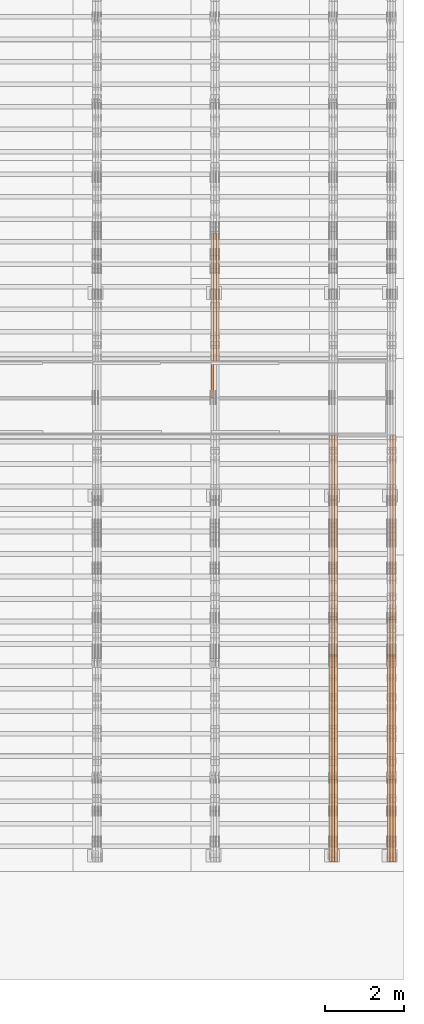
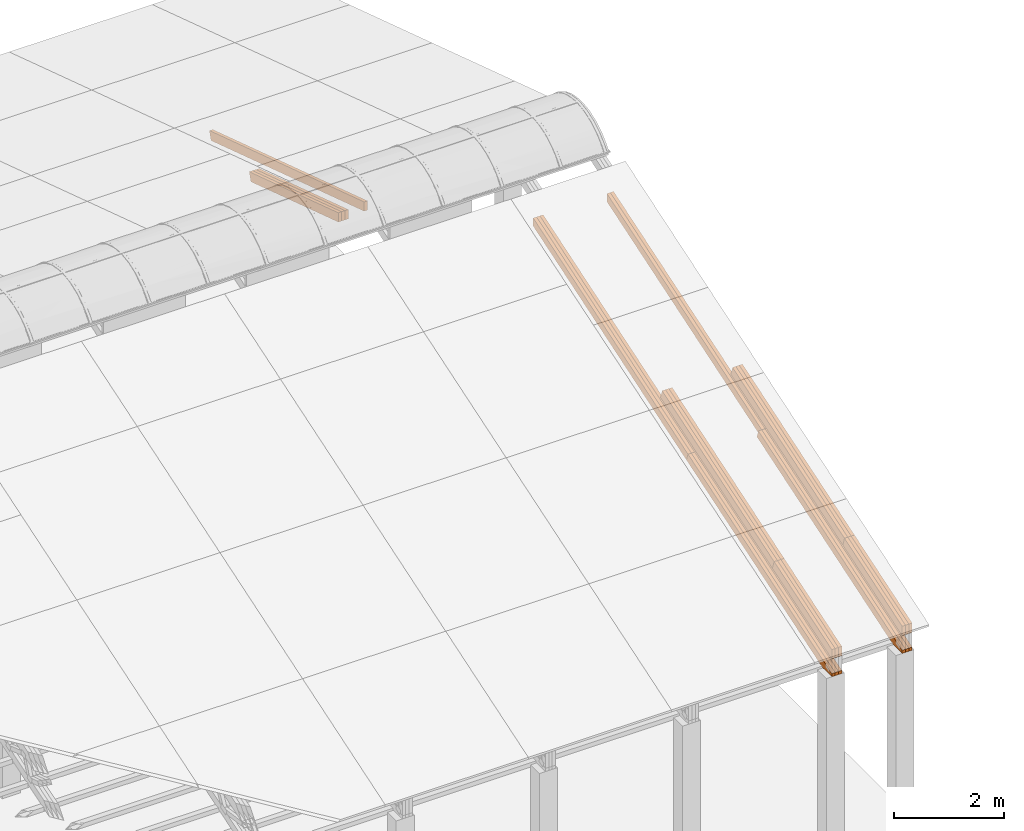
# One storey, part 28 of 385: 27 proxies.
"""IFC2X3 building model written with IfcOpenShell, lengths in millimetres."""

from ifc_helpers import new_model, entity, si_unit, converted_unit, derived_unit, direction, frame, origin, place, context, subcontext, project, spatial, polyline, outline, extrude, source, transform, mapped, material, type_object, type_shapes, element, save


model = new_model("IFC2X3")

# Units and contexts
model_context = context("Model", 3, precision=0.01, world=origin(), true_north=direction((6.12303176911189e-17, 1.0)))
body_context = subcontext(model_context, "Body", "Model", "MODEL_VIEW")
ifc_project = project(units=[si_unit("LENGTHUNIT", "METRE", prefix="MILLI"), si_unit("AREAUNIT", "SQUARE_METRE"), si_unit("VOLUMEUNIT", "CUBIC_METRE"), converted_unit("PLANEANGLEUNIT", "DEGREE", entity("IfcRatioMeasure", 0.0174532925199433), si_unit("PLANEANGLEUNIT", "RADIAN"), dimensions=[0, 0, 0, 0, 0, 0, 0]), si_unit("MASSUNIT", "GRAM", prefix="KILO"), derived_unit("MASSDENSITYUNIT", [(si_unit("MASSUNIT", "GRAM", prefix="KILO"), 1), (si_unit("LENGTHUNIT", "METRE"), -3)]), si_unit("TIMEUNIT", "SECOND"), si_unit("FREQUENCYUNIT", "HERTZ"), si_unit("THERMODYNAMICTEMPERATUREUNIT", "DEGREE_CELSIUS"), derived_unit("THERMALTRANSMITTANCEUNIT", [(si_unit("MASSUNIT", "GRAM", prefix="KILO"), 1), (si_unit("THERMODYNAMICTEMPERATUREUNIT", "KELVIN"), -1), (si_unit("TIMEUNIT", "SECOND"), -3)]), derived_unit("VOLUMETRICFLOWRATEUNIT", [(si_unit("LENGTHUNIT", "METRE"), 3), (si_unit("TIMEUNIT", "SECOND"), -1)]), si_unit("ELECTRICCURRENTUNIT", "AMPERE"), si_unit("ELECTRICVOLTAGEUNIT", "VOLT"), si_unit("POWERUNIT", "WATT"), si_unit("FORCEUNIT", "NEWTON", prefix="KILO"), si_unit("ILLUMINANCEUNIT", "LUX"), si_unit("LUMINOUSFLUXUNIT", "LUMEN"), si_unit("LUMINOUSINTENSITYUNIT", "CANDELA"), derived_unit("USERDEFINED", [(si_unit("MASSUNIT", "GRAM", prefix="KILO"), -1), (si_unit("LENGTHUNIT", "METRE"), -2), (si_unit("TIMEUNIT", "SECOND"), 3), (si_unit("LUMINOUSFLUXUNIT", "LUMEN"), 1)]), derived_unit("LINEARVELOCITYUNIT", [(si_unit("LENGTHUNIT", "METRE"), 1), (si_unit("TIMEUNIT", "SECOND"), -1)]), si_unit("PRESSUREUNIT", "PASCAL"), derived_unit("USERDEFINED", [(si_unit("LENGTHUNIT", "METRE"), -2), (si_unit("MASSUNIT", "GRAM", prefix="KILO"), 1), (si_unit("TIMEUNIT", "SECOND"), -2)])], contexts=[model_context])

# Site, building, storey
site_placement = place(None, origin())
site = spatial("IfcSite", under=ifc_project, at=site_placement, CompositionType="ELEMENT")
building_placement = place(site_placement, origin())
building = spatial("IfcBuilding", under=site, at=building_placement, CompositionType="ELEMENT")
storey_placement = place(building_placement, origin())
storey = spatial("IfcBuildingStorey", under=building, at=storey_placement, Name="Default", CompositionType="ELEMENT", Elevation=0.0)

# Proxies
ifc_material_1 = material(Name="IfcSurfaceStyle #593191")
building_element_proxy_type_1 = type_object("IfcBuildingElementProxyType", Name="T2-T3 593189", PredefinedType="NOTDEFINED", material=ifc_material_1)
shared_shape_1 = source(origin(), body_context, "Body", "SweptSolid", [
    extrude(outline(polyline([(-1085.54462735035, -97.5001496742589), (1117.22361141796, -97.5001496742589), (1117.22498157786, 97.5001496742589), (-1148.90396564547, 97.5001496742589), (-1085.54462735035, -97.5001496742589)])), frame((1117.22498157786, 97.5001496742589, 0.0), z_axis=(0.0, 0.0, 1.0), x_axis=(-1.0, 0.0, 0.0)), (0.0, 0.0, 1.0), 69.9999999999999),
])
type_shapes(building_element_proxy_type_1, [shared_shape_1])
proxy_1_placement = place(building_placement, frame((49860.0, 5095.216796875, 1095.23693847656), z_axis=(-1.0, 0.0, 0.0), x_axis=(0.0, -0.951056516295154, -0.309016994374948)))
element("IfcBuildingElementProxy", 1, at=proxy_1_placement, inside=storey, type_object=building_element_proxy_type_1, material=ifc_material_1, Name="T2-T3", context=body_context, shape_type="MappedRepresentation", body=[
    mapped(shared_shape_1, transform((0.0, 0.0, 0.0), scale=1.0)),
])
ifc_material_2 = material(Name="IfcSurfaceStyle #593134")
building_element_proxy_type_2 = type_object("IfcBuildingElementProxyType", Name="T2-T3 593132", PredefinedType="NOTDEFINED", material=ifc_material_2)
shared_shape_2 = source(origin(), body_context, "Body", "SweptSolid", [
    extrude(outline(polyline([(-1085.54462735035, -97.5001496742589), (1117.22361141796, -97.5001496742589), (1117.22498157786, 97.5001496742589), (-1148.90396564547, 97.5001496742589), (-1085.54462735035, -97.5001496742589)])), frame((1117.22498157786, 97.5001496742589, 0.0), z_axis=(0.0, 0.0, 1.0), x_axis=(-1.0, 0.0, 0.0)), (0.0, 0.0, 1.0), 69.9999999999999),
])
type_shapes(building_element_proxy_type_2, [shared_shape_2])
proxy_2_placement = place(building_placement, frame((49790.0, 5095.216796875, 1095.23693847656), z_axis=(-1.0, 0.0, 0.0), x_axis=(0.0, -0.951056516295154, -0.309016994374948)))
element("IfcBuildingElementProxy", 2, at=proxy_2_placement, inside=storey, type_object=building_element_proxy_type_2, material=ifc_material_2, Name="T2-T3", context=body_context, shape_type="MappedRepresentation", body=[
    mapped(shared_shape_2, transform((0.0, 0.0, 0.0), scale=1.0)),
])
ifc_material_3 = material(Name="IfcSurfaceStyle #593077")
building_element_proxy_type_3 = type_object("IfcBuildingElementProxyType", Name="T2-T3 593075", PredefinedType="NOTDEFINED", material=ifc_material_3)
shared_shape_3 = source(origin(), body_context, "Body", "SweptSolid", [
    extrude(outline(polyline([(-1085.54462735035, -97.5001496742589), (1117.22361141796, -97.5001496742589), (1117.22498157786, 97.5001496742589), (-1148.90396564547, 97.5001496742589), (-1085.54462735035, -97.5001496742589)])), frame((1117.22498157786, 97.5001496742589, 0.0), z_axis=(0.0, 0.0, 1.0), x_axis=(-1.0, 0.0, 0.0)), (0.0, 0.0, 1.0), 69.9999999999999),
])
type_shapes(building_element_proxy_type_3, [shared_shape_3])
proxy_3_placement = place(building_placement, frame((49720.0, 5095.216796875, 1095.23693847656), z_axis=(-1.0, 0.0, 0.0), x_axis=(0.0, -0.951056516295154, -0.309016994374948)))
element("IfcBuildingElementProxy", 3, at=proxy_3_placement, inside=storey, type_object=building_element_proxy_type_3, material=ifc_material_3, Name="T2-T3", context=body_context, shape_type="MappedRepresentation", body=[
    mapped(shared_shape_3, transform((0.0, 0.0, 0.0), scale=1.0)),
])
ifc_material_4 = material(Name="IfcSurfaceStyle #593020")
building_element_proxy_type_4 = type_object("IfcBuildingElementProxyType", Name="T2-T2 593018", PredefinedType="NOTDEFINED", material=ifc_material_4)
shared_shape_4 = source(origin(), body_context, "Body", "SweptSolid", [
    extrude(outline(polyline([(-2137.04475371072, -97.5001541485635), (2137.04431231695, -97.5001541485635), (2137.0438249446, 97.5001541485636), (-2137.04338355082, 97.5001541485635), (-2137.04475371072, -97.5001541485635)])), frame((2137.04431231695, 97.5003268035489, 0.0), z_axis=(0.0, 0.0, 1.0), x_axis=(-1.0, 0.0, 0.0)), (0.0, 0.0, 1.0), 69.9999999999997),
])
type_shapes(building_element_proxy_type_4, [shared_shape_4])
proxy_4_placement = place(building_placement, frame((49860.0, 9160.11575124697, 2416.00267194857), z_axis=(-1.0, 0.0, 0.0), x_axis=(0.0, -0.951056516295154, -0.309016994374948)))
element("IfcBuildingElementProxy", 4, at=proxy_4_placement, inside=storey, type_object=building_element_proxy_type_4, material=ifc_material_4, Name="T2-T2", context=body_context, shape_type="MappedRepresentation", body=[
    mapped(shared_shape_4, transform((0.0, 0.0, 0.0), scale=1.0)),
])
ifc_material_5 = material(Name="IfcSurfaceStyle #592963")
building_element_proxy_type_5 = type_object("IfcBuildingElementProxyType", Name="T2-T2 592961", PredefinedType="NOTDEFINED", material=ifc_material_5)
shared_shape_5 = source(origin(), body_context, "Body", "SweptSolid", [
    extrude(outline(polyline([(-2137.04475371072, -97.5001541485635), (2137.04431231695, -97.5001541485635), (2137.0438249446, 97.5001541485636), (-2137.04338355082, 97.5001541485635), (-2137.04475371072, -97.5001541485635)])), frame((2137.04431231695, 97.5003268035489, 0.0), z_axis=(0.0, 0.0, 1.0), x_axis=(-1.0, 0.0, 0.0)), (0.0, 0.0, 1.0), 69.9999999999997),
])
type_shapes(building_element_proxy_type_5, [shared_shape_5])
proxy_5_placement = place(building_placement, frame((49790.0, 9160.11575124697, 2416.00267194857), z_axis=(-1.0, 0.0, 0.0), x_axis=(0.0, -0.951056516295154, -0.309016994374948)))
element("IfcBuildingElementProxy", 5, at=proxy_5_placement, inside=storey, type_object=building_element_proxy_type_5, material=ifc_material_5, Name="T2-T2", context=body_context, shape_type="MappedRepresentation", body=[
    mapped(shared_shape_5, transform((0.0, 0.0, 0.0), scale=1.0)),
])
ifc_material_6 = material(Name="IfcSurfaceStyle #592906")
building_element_proxy_type_6 = type_object("IfcBuildingElementProxyType", Name="T2-T2 592904", PredefinedType="NOTDEFINED", material=ifc_material_6)
shared_shape_6 = source(origin(), body_context, "Body", "SweptSolid", [
    extrude(outline(polyline([(-2137.04475371072, -97.5001541485635), (2137.04431231695, -97.5001541485635), (2137.0438249446, 97.5001541485636), (-2137.04338355082, 97.5001541485635), (-2137.04475371072, -97.5001541485635)])), frame((2137.04431231695, 97.5003268035489, 0.0), z_axis=(0.0, 0.0, 1.0), x_axis=(-1.0, 0.0, 0.0)), (0.0, 0.0, 1.0), 69.9999999999997),
])
type_shapes(building_element_proxy_type_6, [shared_shape_6])
proxy_6_placement = place(building_placement, frame((49720.0, 9160.11575124697, 2416.00267194857), z_axis=(-1.0, 0.0, 0.0), x_axis=(0.0, -0.951056516295154, -0.309016994374948)))
element("IfcBuildingElementProxy", 6, at=proxy_6_placement, inside=storey, type_object=building_element_proxy_type_6, material=ifc_material_6, Name="T2-T2", context=body_context, shape_type="MappedRepresentation", body=[
    mapped(shared_shape_6, transform((0.0, 0.0, 0.0), scale=1.0)),
])
ifc_material_7 = material(Name="IfcSurfaceStyle #592678")
building_element_proxy_type_7 = type_object("IfcBuildingElementProxyType", Name="T2-B4 592676", PredefinedType="NOTDEFINED", material=ifc_material_7)
shared_shape_7 = source(origin(), body_context, "Body", "SweptSolid", [
    extrude(outline(polyline([(-2912.13310129284, -85.0000958683222), (2939.75111293783, -85.0000958683222), (2939.75142473078, 85.0000958683222), (-2967.36943637577, 85.0000958683222), (-2912.13310129284, -85.0000958683222)])), frame((2939.75142473078, 85.0000958683222, 0.0), z_axis=(0.0, 0.0, 1.0), x_axis=(-1.0, 0.0, 0.0)), (0.0, 0.0, 1.0), 69.9999999999996),
])
type_shapes(building_element_proxy_type_7, [shared_shape_7])
proxy_7_placement = place(building_placement, frame((49860.0, 8161.994140625, 1765.00476074219), z_axis=(-1.0, 0.0, 0.0), x_axis=(0.0, 0.951056516295124, 0.309016994375039)))
element("IfcBuildingElementProxy", 7, at=proxy_7_placement, inside=storey, type_object=building_element_proxy_type_7, material=ifc_material_7, Name="T2-B4", context=body_context, shape_type="MappedRepresentation", body=[
    mapped(shared_shape_7, transform((0.0, 0.0, 0.0), scale=1.0)),
])
ifc_material_8 = material(Name="IfcSurfaceStyle #592621")
building_element_proxy_type_8 = type_object("IfcBuildingElementProxyType", Name="T2-B4 592619", PredefinedType="NOTDEFINED", material=ifc_material_8)
shared_shape_8 = source(origin(), body_context, "Body", "SweptSolid", [
    extrude(outline(polyline([(-2912.13310129284, -85.0000958683222), (2939.75111293783, -85.0000958683222), (2939.75142473078, 85.0000958683222), (-2967.36943637577, 85.0000958683222), (-2912.13310129284, -85.0000958683222)])), frame((2939.75142473078, 85.0000958683222, 0.0), z_axis=(0.0, 0.0, 1.0), x_axis=(-1.0, 0.0, 0.0)), (0.0, 0.0, 1.0), 69.9999999999996),
])
type_shapes(building_element_proxy_type_8, [shared_shape_8])
proxy_8_placement = place(building_placement, frame((49790.0, 8161.994140625, 1765.00476074219), z_axis=(-1.0, 0.0, 0.0), x_axis=(0.0, 0.951056516295124, 0.309016994375039)))
element("IfcBuildingElementProxy", 8, at=proxy_8_placement, inside=storey, type_object=building_element_proxy_type_8, material=ifc_material_8, Name="T2-B4", context=body_context, shape_type="MappedRepresentation", body=[
    mapped(shared_shape_8, transform((0.0, 0.0, 0.0), scale=1.0)),
])
ifc_material_9 = material(Name="IfcSurfaceStyle #592507")
building_element_proxy_type_9 = type_object("IfcBuildingElementProxyType", Name="T2-B5 592505", PredefinedType="NOTDEFINED", material=ifc_material_9)
shared_shape_9 = source(origin(), body_context, "Body", "SweptSolid", [
    extrude(outline(polyline([(-3238.20553797979, -89.0131148793731), (1950.26357999126, -89.0131148793731), (2273.6227955316, 16.0525968934038), (2252.52438864378, 80.9868164326712), (-3238.20522618685, 80.9868164326712), (-3238.20553797979, -89.0131148793731)])), frame((2273.6227955316, 80.9869419088758, 0.0), z_axis=(0.0, 0.0, 1.0), x_axis=(-1.0, 0.0, 0.0)), (0.0, 0.0, 1.0), 69.9999999999997),
])
type_shapes(building_element_proxy_type_9, [shared_shape_9])
proxy_9_placement = place(building_placement, frame((49860.0, 2919.93418387161, 61.7562319586341), z_axis=(-1.0, 0.0, 0.0), x_axis=(0.0, 0.951056516295124, 0.309016994375039)))
element("IfcBuildingElementProxy", 9, at=proxy_9_placement, inside=storey, type_object=building_element_proxy_type_9, material=ifc_material_9, Name="T2-B5", context=body_context, shape_type="MappedRepresentation", body=[
    mapped(shared_shape_9, transform((0.0, 0.0, 0.0), scale=1.0)),
])
ifc_material_10 = material(Name="IfcSurfaceStyle #592441")
building_element_proxy_type_10 = type_object("IfcBuildingElementProxyType", Name="T2-B5 592439", PredefinedType="NOTDEFINED", material=ifc_material_10)
shared_shape_10 = source(origin(), body_context, "Body", "SweptSolid", [
    extrude(outline(polyline([(-3238.20553797979, -89.0131148793731), (1950.26357999126, -89.0131148793731), (2273.6227955316, 16.0525968934038), (2252.52438864378, 80.9868164326712), (-3238.20522618685, 80.9868164326712), (-3238.20553797979, -89.0131148793731)])), frame((2273.6227955316, 80.9869419088758, 0.0), z_axis=(0.0, 0.0, 1.0), x_axis=(-1.0, 0.0, 0.0)), (0.0, 0.0, 1.0), 69.9999999999997),
])
type_shapes(building_element_proxy_type_10, [shared_shape_10])
proxy_10_placement = place(building_placement, frame((49790.0, 2919.93418387161, 61.7562319586341), z_axis=(-1.0, 0.0, 0.0), x_axis=(0.0, 0.951056516295124, 0.309016994375039)))
element("IfcBuildingElementProxy", 10, at=proxy_10_placement, inside=storey, type_object=building_element_proxy_type_10, material=ifc_material_10, Name="T2-B5", context=body_context, shape_type="MappedRepresentation", body=[
    mapped(shared_shape_10, transform((0.0, 0.0, 0.0), scale=1.0)),
])
ifc_material_11 = material(Name="IfcSurfaceStyle #592375")
building_element_proxy_type_11 = type_object("IfcBuildingElementProxyType", Name="T2-B5 592373", PredefinedType="NOTDEFINED", material=ifc_material_11)
shared_shape_11 = source(origin(), body_context, "Body", "SweptSolid", [
    extrude(outline(polyline([(-3238.20553797979, -89.0131148793731), (1950.26357999126, -89.0131148793731), (2273.6227955316, 16.0525968934038), (2252.52438864378, 80.9868164326712), (-3238.20522618685, 80.9868164326712), (-3238.20553797979, -89.0131148793731)])), frame((2273.6227955316, 80.9869419088758, 0.0), z_axis=(0.0, 0.0, 1.0), x_axis=(-1.0, 0.0, 0.0)), (0.0, 0.0, 1.0), 69.9999999999997),
])
type_shapes(building_element_proxy_type_11, [shared_shape_11])
proxy_11_placement = place(building_placement, frame((49720.0, 2919.93418387161, 61.7562319586341), z_axis=(-1.0, 0.0, 0.0), x_axis=(0.0, 0.951056516295124, 0.309016994375039)))
element("IfcBuildingElementProxy", 11, at=proxy_11_placement, inside=storey, type_object=building_element_proxy_type_11, material=ifc_material_11, Name="T2-B5", context=body_context, shape_type="MappedRepresentation", body=[
    mapped(shared_shape_11, transform((0.0, 0.0, 0.0), scale=1.0)),
])
ifc_material_12 = material(Name="IfcSurfaceStyle #558759")
building_element_proxy_type_12 = type_object("IfcBuildingElementProxyType", Name="T1-T3 558757", PredefinedType="NOTDEFINED", material=ifc_material_12)
shared_shape_12 = source(origin(), body_context, "Body", "SweptSolid", [
    extrude(outline(polyline([(-1085.54462735035, -97.5001496742589), (1117.22361141796, -97.5001496742589), (1117.22498157786, 97.5001496742589), (-1148.90396564547, 97.5001496742589), (-1085.54462735035, -97.5001496742589)])), frame((1117.22498157786, 97.5001496742589, 0.0), z_axis=(0.0, 0.0, 1.0), x_axis=(-1.0, 0.0, 0.0)), (0.0, 0.0, 1.0), 69.9999999999999),
])
type_shapes(building_element_proxy_type_12, [shared_shape_12])
proxy_12_placement = place(building_placement, frame((48385.0, 5095.216796875, 1095.23693847656), z_axis=(-1.0, 0.0, 0.0), x_axis=(0.0, -0.951056516295154, -0.309016994374948)))
element("IfcBuildingElementProxy", 12, at=proxy_12_placement, inside=storey, type_object=building_element_proxy_type_12, material=ifc_material_12, Name="T1-T3", context=body_context, shape_type="MappedRepresentation", body=[
    mapped(shared_shape_12, transform((0.0, 0.0, 0.0), scale=1.0)),
])
ifc_material_13 = material(Name="IfcSurfaceStyle #558702")
building_element_proxy_type_13 = type_object("IfcBuildingElementProxyType", Name="T1-T3 558700", PredefinedType="NOTDEFINED", material=ifc_material_13)
shared_shape_13 = source(origin(), body_context, "Body", "SweptSolid", [
    extrude(outline(polyline([(-1085.54462735035, -97.5001496742589), (1117.22361141796, -97.5001496742589), (1117.22498157786, 97.5001496742589), (-1148.90396564547, 97.5001496742589), (-1085.54462735035, -97.5001496742589)])), frame((1117.22498157786, 97.5001496742589, 0.0), z_axis=(0.0, 0.0, 1.0), x_axis=(-1.0, 0.0, 0.0)), (0.0, 0.0, 1.0), 69.9999999999999),
])
type_shapes(building_element_proxy_type_13, [shared_shape_13])
proxy_13_placement = place(building_placement, frame((48315.0, 5095.216796875, 1095.23693847656), z_axis=(-1.0, 0.0, 0.0), x_axis=(0.0, -0.951056516295154, -0.309016994374948)))
element("IfcBuildingElementProxy", 13, at=proxy_13_placement, inside=storey, type_object=building_element_proxy_type_13, material=ifc_material_13, Name="T1-T3", context=body_context, shape_type="MappedRepresentation", body=[
    mapped(shared_shape_13, transform((0.0, 0.0, 0.0), scale=1.0)),
])
ifc_material_14 = material(Name="IfcSurfaceStyle #558645")
building_element_proxy_type_14 = type_object("IfcBuildingElementProxyType", Name="T1-T3 558643", PredefinedType="NOTDEFINED", material=ifc_material_14)
shared_shape_14 = source(origin(), body_context, "Body", "SweptSolid", [
    extrude(outline(polyline([(-1085.54462735035, -97.5001496742589), (1117.22361141796, -97.5001496742589), (1117.22498157786, 97.5001496742589), (-1148.90396564547, 97.5001496742589), (-1085.54462735035, -97.5001496742589)])), frame((1117.22498157786, 97.5001496742589, 0.0), z_axis=(0.0, 0.0, 1.0), x_axis=(-1.0, 0.0, 0.0)), (0.0, 0.0, 1.0), 69.9999999999999),
])
type_shapes(building_element_proxy_type_14, [shared_shape_14])
proxy_14_placement = place(building_placement, frame((48245.0, 5095.216796875, 1095.23693847656), z_axis=(-1.0, 0.0, 0.0), x_axis=(0.0, -0.951056516295154, -0.309016994374948)))
element("IfcBuildingElementProxy", 14, at=proxy_14_placement, inside=storey, type_object=building_element_proxy_type_14, material=ifc_material_14, Name="T1-T3", context=body_context, shape_type="MappedRepresentation", body=[
    mapped(shared_shape_14, transform((0.0, 0.0, 0.0), scale=1.0)),
])
ifc_material_15 = material(Name="IfcSurfaceStyle #558588")
building_element_proxy_type_15 = type_object("IfcBuildingElementProxyType", Name="T1-T2 558586", PredefinedType="NOTDEFINED", material=ifc_material_15)
shared_shape_15 = source(origin(), body_context, "Body", "SweptSolid", [
    extrude(outline(polyline([(-2137.04475371072, -97.5001541485635), (2137.04431231695, -97.5001541485635), (2137.0438249446, 97.5001541485636), (-2137.04338355082, 97.5001541485635), (-2137.04475371072, -97.5001541485635)])), frame((2137.04431231695, 97.5003268035489, 0.0), z_axis=(0.0, 0.0, 1.0), x_axis=(-1.0, 0.0, 0.0)), (0.0, 0.0, 1.0), 69.9999999999997),
])
type_shapes(building_element_proxy_type_15, [shared_shape_15])
proxy_15_placement = place(building_placement, frame((48385.0, 9160.11575124698, 2416.00267194857), z_axis=(-1.0, 0.0, 0.0), x_axis=(0.0, -0.951056516295154, -0.309016994374948)))
element("IfcBuildingElementProxy", 15, at=proxy_15_placement, inside=storey, type_object=building_element_proxy_type_15, material=ifc_material_15, Name="T1-T2", context=body_context, shape_type="MappedRepresentation", body=[
    mapped(shared_shape_15, transform((0.0, 0.0, 0.0), scale=1.0)),
])
ifc_material_16 = material(Name="IfcSurfaceStyle #558531")
building_element_proxy_type_16 = type_object("IfcBuildingElementProxyType", Name="T1-T2 558529", PredefinedType="NOTDEFINED", material=ifc_material_16)
shared_shape_16 = source(origin(), body_context, "Body", "SweptSolid", [
    extrude(outline(polyline([(-2137.04475371072, -97.5001541485635), (2137.04431231695, -97.5001541485635), (2137.0438249446, 97.5001541485636), (-2137.04338355082, 97.5001541485635), (-2137.04475371072, -97.5001541485635)])), frame((2137.04431231695, 97.5003268035489, 0.0), z_axis=(0.0, 0.0, 1.0), x_axis=(-1.0, 0.0, 0.0)), (0.0, 0.0, 1.0), 69.9999999999997),
])
type_shapes(building_element_proxy_type_16, [shared_shape_16])
proxy_16_placement = place(building_placement, frame((48315.0, 9160.11575124698, 2416.00267194857), z_axis=(-1.0, 0.0, 0.0), x_axis=(0.0, -0.951056516295154, -0.309016994374948)))
element("IfcBuildingElementProxy", 16, at=proxy_16_placement, inside=storey, type_object=building_element_proxy_type_16, material=ifc_material_16, Name="T1-T2", context=body_context, shape_type="MappedRepresentation", body=[
    mapped(shared_shape_16, transform((0.0, 0.0, 0.0), scale=1.0)),
])
ifc_material_17 = material(Name="IfcSurfaceStyle #558474")
building_element_proxy_type_17 = type_object("IfcBuildingElementProxyType", Name="T1-T2 558472", PredefinedType="NOTDEFINED", material=ifc_material_17)
shared_shape_17 = source(origin(), body_context, "Body", "SweptSolid", [
    extrude(outline(polyline([(-2137.04475371072, -97.5001541485635), (2137.04431231695, -97.5001541485635), (2137.0438249446, 97.5001541485636), (-2137.04338355082, 97.5001541485635), (-2137.04475371072, -97.5001541485635)])), frame((2137.04431231695, 97.5003268035489, 0.0), z_axis=(0.0, 0.0, 1.0), x_axis=(-1.0, 0.0, 0.0)), (0.0, 0.0, 1.0), 69.9999999999997),
])
type_shapes(building_element_proxy_type_17, [shared_shape_17])
proxy_17_placement = place(building_placement, frame((48245.0, 9160.11575124698, 2416.00267194857), z_axis=(-1.0, 0.0, 0.0), x_axis=(0.0, -0.951056516295154, -0.309016994374948)))
element("IfcBuildingElementProxy", 17, at=proxy_17_placement, inside=storey, type_object=building_element_proxy_type_17, material=ifc_material_17, Name="T1-T2", context=body_context, shape_type="MappedRepresentation", body=[
    mapped(shared_shape_17, transform((0.0, 0.0, 0.0), scale=1.0)),
])
ifc_material_18 = material(Name="IfcSurfaceStyle #558246")
building_element_proxy_type_18 = type_object("IfcBuildingElementProxyType", Name="T1-B4 558244", PredefinedType="NOTDEFINED", material=ifc_material_18)
shared_shape_18 = source(origin(), body_context, "Body", "SweptSolid", [
    extrude(outline(polyline([(-2912.13310129284, -85.0000958683222), (2939.75111293783, -85.0000958683222), (2939.75142473078, 85.0000958683222), (-2967.36943637577, 85.0000958683222), (-2912.13310129284, -85.0000958683222)])), frame((2939.75142473078, 85.0000958683222, 0.0), z_axis=(0.0, 0.0, 1.0), x_axis=(-1.0, 0.0, 0.0)), (0.0, 0.0, 1.0), 69.9999999999996),
])
type_shapes(building_element_proxy_type_18, [shared_shape_18])
proxy_18_placement = place(building_placement, frame((48385.0, 8161.99414062501, 1765.00476074219), z_axis=(-1.0, 0.0, 0.0), x_axis=(0.0, 0.951056516295124, 0.309016994375039)))
element("IfcBuildingElementProxy", 18, at=proxy_18_placement, inside=storey, type_object=building_element_proxy_type_18, material=ifc_material_18, Name="T1-B4", context=body_context, shape_type="MappedRepresentation", body=[
    mapped(shared_shape_18, transform((0.0, 0.0, 0.0), scale=1.0)),
])
ifc_material_19 = material(Name="IfcSurfaceStyle #558189")
building_element_proxy_type_19 = type_object("IfcBuildingElementProxyType", Name="T1-B4 558187", PredefinedType="NOTDEFINED", material=ifc_material_19)
shared_shape_19 = source(origin(), body_context, "Body", "SweptSolid", [
    extrude(outline(polyline([(-2912.13310129284, -85.0000958683222), (2939.75111293783, -85.0000958683222), (2939.75142473078, 85.0000958683222), (-2967.36943637577, 85.0000958683222), (-2912.13310129284, -85.0000958683222)])), frame((2939.75142473078, 85.0000958683222, 0.0), z_axis=(0.0, 0.0, 1.0), x_axis=(-1.0, 0.0, 0.0)), (0.0, 0.0, 1.0), 69.9999999999996),
])
type_shapes(building_element_proxy_type_19, [shared_shape_19])
proxy_19_placement = place(building_placement, frame((48315.0, 8161.99414062501, 1765.00476074219), z_axis=(-1.0, 0.0, 0.0), x_axis=(0.0, 0.951056516295124, 0.309016994375039)))
element("IfcBuildingElementProxy", 19, at=proxy_19_placement, inside=storey, type_object=building_element_proxy_type_19, material=ifc_material_19, Name="T1-B4", context=body_context, shape_type="MappedRepresentation", body=[
    mapped(shared_shape_19, transform((0.0, 0.0, 0.0), scale=1.0)),
])
ifc_material_20 = material(Name="IfcSurfaceStyle #558132")
building_element_proxy_type_20 = type_object("IfcBuildingElementProxyType", Name="T1-B4 558130", PredefinedType="NOTDEFINED", material=ifc_material_20)
shared_shape_20 = source(origin(), body_context, "Body", "SweptSolid", [
    extrude(outline(polyline([(-2912.13310129284, -85.0000958683222), (2939.75111293783, -85.0000958683222), (2939.75142473078, 85.0000958683222), (-2967.36943637577, 85.0000958683222), (-2912.13310129284, -85.0000958683222)])), frame((2939.75142473078, 85.0000958683222, 0.0), z_axis=(0.0, 0.0, 1.0), x_axis=(-1.0, 0.0, 0.0)), (0.0, 0.0, 1.0), 69.9999999999996),
])
type_shapes(building_element_proxy_type_20, [shared_shape_20])
proxy_20_placement = place(building_placement, frame((48245.0, 8161.99414062501, 1765.00476074219), z_axis=(-1.0, 0.0, 0.0), x_axis=(0.0, 0.951056516295124, 0.309016994375039)))
element("IfcBuildingElementProxy", 20, at=proxy_20_placement, inside=storey, type_object=building_element_proxy_type_20, material=ifc_material_20, Name="T1-B4", context=body_context, shape_type="MappedRepresentation", body=[
    mapped(shared_shape_20, transform((0.0, 0.0, 0.0), scale=1.0)),
])
ifc_material_21 = material(Name="IfcSurfaceStyle #558075")
building_element_proxy_type_21 = type_object("IfcBuildingElementProxyType", Name="T1-B5 558073", PredefinedType="NOTDEFINED", material=ifc_material_21)
shared_shape_21 = source(origin(), body_context, "Body", "SweptSolid", [
    extrude(outline(polyline([(-3238.20553797979, -89.0131148793731), (1950.26357999126, -89.0131148793731), (2273.6227955316, 16.0525968934038), (2252.52438864378, 80.9868164326712), (-3238.20522618685, 80.9868164326712), (-3238.20553797979, -89.0131148793731)])), frame((2273.6227955316, 80.9869419088758, 0.0), z_axis=(0.0, 0.0, 1.0), x_axis=(-1.0, 0.0, 0.0)), (0.0, 0.0, 1.0), 69.9999999999997),
])
type_shapes(building_element_proxy_type_21, [shared_shape_21])
proxy_21_placement = place(building_placement, frame((48385.0, 2919.93418387162, 61.7562319586341), z_axis=(-1.0, 0.0, 0.0), x_axis=(0.0, 0.951056516295124, 0.309016994375039)))
element("IfcBuildingElementProxy", 21, at=proxy_21_placement, inside=storey, type_object=building_element_proxy_type_21, material=ifc_material_21, Name="T1-B5", context=body_context, shape_type="MappedRepresentation", body=[
    mapped(shared_shape_21, transform((0.0, 0.0, 0.0), scale=1.0)),
])
ifc_material_22 = material(Name="IfcSurfaceStyle #558009")
building_element_proxy_type_22 = type_object("IfcBuildingElementProxyType", Name="T1-B5 558007", PredefinedType="NOTDEFINED", material=ifc_material_22)
shared_shape_22 = source(origin(), body_context, "Body", "SweptSolid", [
    extrude(outline(polyline([(-3238.20553797979, -89.0131148793731), (1950.26357999126, -89.0131148793731), (2273.6227955316, 16.0525968934038), (2252.52438864378, 80.9868164326712), (-3238.20522618685, 80.9868164326712), (-3238.20553797979, -89.0131148793731)])), frame((2273.6227955316, 80.9869419088758, 0.0), z_axis=(0.0, 0.0, 1.0), x_axis=(-1.0, 0.0, 0.0)), (0.0, 0.0, 1.0), 69.9999999999997),
])
type_shapes(building_element_proxy_type_22, [shared_shape_22])
proxy_22_placement = place(building_placement, frame((48315.0, 2919.93418387162, 61.7562319586341), z_axis=(-1.0, 0.0, 0.0), x_axis=(0.0, 0.951056516295124, 0.309016994375039)))
element("IfcBuildingElementProxy", 22, at=proxy_22_placement, inside=storey, type_object=building_element_proxy_type_22, material=ifc_material_22, Name="T1-B5", context=body_context, shape_type="MappedRepresentation", body=[
    mapped(shared_shape_22, transform((0.0, 0.0, 0.0), scale=1.0)),
])
ifc_material_23 = material(Name="IfcSurfaceStyle #557943")
building_element_proxy_type_23 = type_object("IfcBuildingElementProxyType", Name="T1-B5 557941", PredefinedType="NOTDEFINED", material=ifc_material_23)
shared_shape_23 = source(origin(), body_context, "Body", "SweptSolid", [
    extrude(outline(polyline([(-3238.20553797979, -89.0131148793731), (1950.26357999126, -89.0131148793731), (2273.6227955316, 16.0525968934038), (2252.52438864378, 80.9868164326712), (-3238.20522618685, 80.9868164326712), (-3238.20553797979, -89.0131148793731)])), frame((2273.6227955316, 80.9869419088758, 0.0), z_axis=(0.0, 0.0, 1.0), x_axis=(-1.0, 0.0, 0.0)), (0.0, 0.0, 1.0), 69.9999999999997),
])
type_shapes(building_element_proxy_type_23, [shared_shape_23])
proxy_23_placement = place(building_placement, frame((48245.0, 2919.93418387162, 61.7562319586341), z_axis=(-1.0, 0.0, 0.0), x_axis=(0.0, 0.951056516295124, 0.309016994375039)))
element("IfcBuildingElementProxy", 23, at=proxy_23_placement, inside=storey, type_object=building_element_proxy_type_23, material=ifc_material_23, Name="T1-B5", context=body_context, shape_type="MappedRepresentation", body=[
    mapped(shared_shape_23, transform((0.0, 0.0, 0.0), scale=1.0)),
])
ifc_material_24 = material(Name="IfcSurfaceStyle #524726")
building_element_proxy_type_24 = type_object("IfcBuildingElementProxyType", Name="T1-T1 524724", PredefinedType="NOTDEFINED", material=ifc_material_24)
shared_shape_24 = source(origin(), body_context, "Body", "SweptSolid", [
    extrude(outline(polyline([(-2970.52406677137, -97.5001477982598), (2938.84461360547, -97.5001477982598), (2938.8441722117, 97.5001477982599), (-2907.1647190458, 97.5001477982598), (-2970.52406677137, -97.5001477982598)])), frame((2938.84461360547, 97.5001477982598, 0.0), z_axis=(0.0, 0.0, 1.0), x_axis=(-1.0, 0.0, 0.0)), (0.0, 0.0, 1.0), 69.9999999999996),
])
type_shapes(building_element_proxy_type_24, [shared_shape_24])
proxy_24_placement = place(building_placement, frame((45245.0, 20279.8851854154, 2416.0025491487), z_axis=(-1.0, 0.0, 0.0), x_axis=(0.0, -0.951056516295154, 0.309016994374948)))
element("IfcBuildingElementProxy", 24, at=proxy_24_placement, inside=storey, type_object=building_element_proxy_type_24, material=ifc_material_24, Name="T1-T1", context=body_context, shape_type="MappedRepresentation", body=[
    mapped(shared_shape_24, transform((0.0, 0.0, 0.0), scale=1.0)),
])
ifc_material_25 = material(Name="IfcSurfaceStyle #523445")
building_element_proxy_type_25 = type_object("IfcBuildingElementProxyType", Name="T1-B3 523443", PredefinedType="NOTDEFINED", material=ifc_material_25)
shared_shape_25 = source(origin(), body_context, "Body", "SweptSolid", [
    extrude(outline(polyline([(-1715.8757175801, -97.4999653079672), (1684.19580003112, -97.4999653079672), (1684.19628740349, 97.4999653079672), (-1652.51636985451, 97.4999653079672), (-1715.8757175801, -97.4999653079672)])), frame((1684.19628740349, 97.5000561131842, 0.0), z_axis=(0.0, 0.0, 1.0), x_axis=(-1.0, 0.0, 0.0)), (0.0, 0.0, 1.0), 69.9999999999998),
])
type_shapes(building_element_proxy_type_25, [shared_shape_25])
proxy_25_placement = place(building_placement, frame((45385.0, 18833.4023156897, 2380.55582184223), z_axis=(-1.0, 0.0, 0.0), x_axis=(0.0, -0.951056516295124, 0.309016994375039)))
element("IfcBuildingElementProxy", 25, at=proxy_25_placement, inside=storey, type_object=building_element_proxy_type_25, material=ifc_material_25, Name="T1-B3", context=body_context, shape_type="MappedRepresentation", body=[
    mapped(shared_shape_25, transform((0.0, 0.0, 0.0), scale=1.0)),
])
ifc_material_26 = material(Name="IfcSurfaceStyle #523388")
building_element_proxy_type_26 = type_object("IfcBuildingElementProxyType", Name="T1-B3 523386", PredefinedType="NOTDEFINED", material=ifc_material_26)
shared_shape_26 = source(origin(), body_context, "Body", "SweptSolid", [
    extrude(outline(polyline([(-1715.8757175801, -97.4999653079672), (1684.19580003112, -97.4999653079672), (1684.19628740349, 97.4999653079672), (-1652.51636985451, 97.4999653079672), (-1715.8757175801, -97.4999653079672)])), frame((1684.19628740349, 97.5000561131842, 0.0), z_axis=(0.0, 0.0, 1.0), x_axis=(-1.0, 0.0, 0.0)), (0.0, 0.0, 1.0), 69.9999999999998),
])
type_shapes(building_element_proxy_type_26, [shared_shape_26])
proxy_26_placement = place(building_placement, frame((45315.0, 18833.4023156897, 2380.55582184223), z_axis=(-1.0, 0.0, 0.0), x_axis=(0.0, -0.951056516295124, 0.309016994375039)))
element("IfcBuildingElementProxy", 26, at=proxy_26_placement, inside=storey, type_object=building_element_proxy_type_26, material=ifc_material_26, Name="T1-B3", context=body_context, shape_type="MappedRepresentation", body=[
    mapped(shared_shape_26, transform((0.0, 0.0, 0.0), scale=1.0)),
])
ifc_material_27 = material(Name="IfcSurfaceStyle #523331")
building_element_proxy_type_27 = type_object("IfcBuildingElementProxyType", Name="T1-B3 523329", PredefinedType="NOTDEFINED", material=ifc_material_27)
shared_shape_27 = source(origin(), body_context, "Body", "SweptSolid", [
    extrude(outline(polyline([(-1715.8757175801, -97.4999653079672), (1684.19580003112, -97.4999653079672), (1684.19628740349, 97.4999653079672), (-1652.51636985451, 97.4999653079672), (-1715.8757175801, -97.4999653079672)])), frame((1684.19628740349, 97.5000561131842, 0.0), z_axis=(0.0, 0.0, 1.0), x_axis=(-1.0, 0.0, 0.0)), (0.0, 0.0, 1.0), 69.9999999999998),
])
type_shapes(building_element_proxy_type_27, [shared_shape_27])
proxy_27_placement = place(building_placement, frame((45245.0, 18833.4023156897, 2380.55582184223), z_axis=(-1.0, 0.0, 0.0), x_axis=(0.0, -0.951056516295124, 0.309016994375039)))
element("IfcBuildingElementProxy", 27, at=proxy_27_placement, inside=storey, type_object=building_element_proxy_type_27, material=ifc_material_27, Name="T1-B3", context=body_context, shape_type="MappedRepresentation", body=[
    mapped(shared_shape_27, transform((0.0, 0.0, 0.0), scale=1.0)),
])

save(model, "model.ifc")
